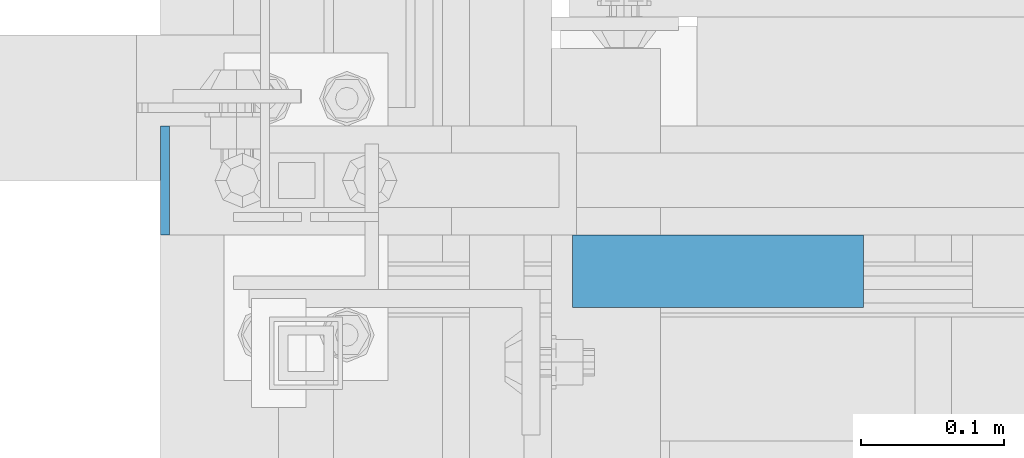
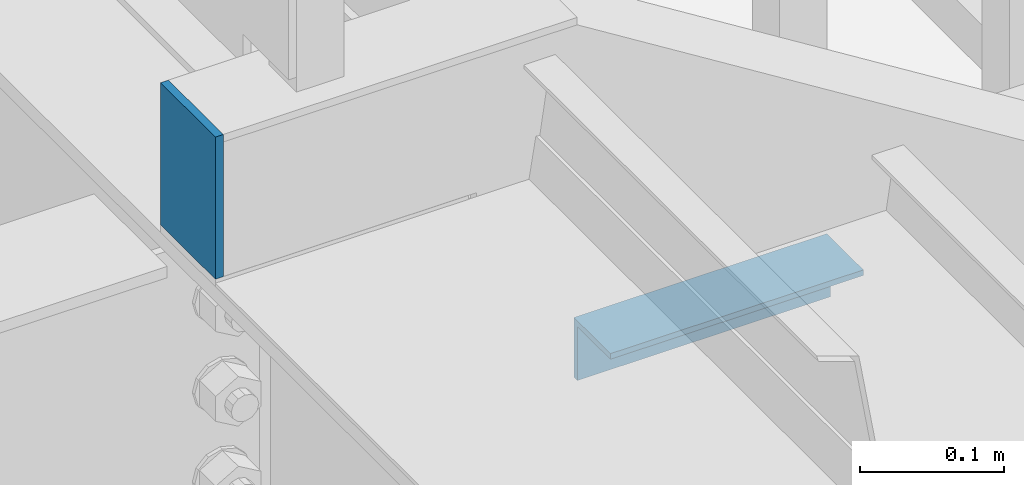
# One storey, part 2073 of 3843: 2 beams, 1 element without a shape of its own.
"""IFC2X3 building model written with IfcOpenShell, lengths in millimetres."""

import ifcopenshell
import ifcopenshell.guid

model = None  # the IFC model being written
_history = None  # IfcOwnerHistory: only IFC2X3 demands one
_inside = {}  # id of a spatial element -> (the spatial element, [elements in it])
_under = {}  # id of a project, library or spatial element -> (it, [spatial elements below it])
_declared = {}  # id of a project -> (the project, [libraries it declares])
_typed = {}  # id of a type object -> (the type object, [elements of that type])
_made_of = {}  # id of a material, layer set ... -> (it, [elements and type objects made of it])


def new_model(schema):
    """Start an empty IFC model of exactly this schema.

    Asked for "IFC4X3", IfcOpenShell would pick the latest addendum, in which some entities
    have other attributes; the version numbers below select the first issue.
    IFC2X3 requires an IfcOwnerHistory on every rooted entity: one is made here for all.
    """
    global model, _history
    if schema == "IFC4X3":
        model = ifcopenshell.file(schema_version=(4, 3, 0, 0))
    else:
        model = ifcopenshell.file(schema=schema)
    _inside.clear()
    _under.clear()
    _declared.clear()
    _typed.clear()
    _made_of.clear()
    _history = None
    if model.schema == "IFC2X3":
        org = make("IfcOrganization", Name="unknown")
        user = make(
            "IfcPersonAndOrganization",
            ThePerson=make("IfcPerson", FamilyName="unknown"),
            TheOrganization=org,
        )
        app = make(
            "IfcApplication",
            ApplicationDeveloper=org,
            Version="unknown",
            ApplicationFullName="unknown",
            ApplicationIdentifier="unknown",
        )
        _history = make(
            "IfcOwnerHistory",
            OwningUser=user,
            OwningApplication=app,
            ChangeAction="ADDED",
            CreationDate=0,
        )
    return model


def make(cls, **values):
    """One entity of the class cls with the attributes given. An attribute that is None is left unset."""
    return model.create_entity(
        cls, **{name: value for name, value in values.items() if value is not None}
    )


def rooted(cls, **values):
    """An entity with a GlobalId (a new one), such as an element, a storey or a relation."""
    return make(cls, GlobalId=ifcopenshell.guid.new(), OwnerHistory=_history, **values)


def si_unit(unit_type, name, prefix=None):
    """IfcSIUnit, for example si_unit("LENGTHUNIT", "METRE", prefix="MILLI")."""
    return make("IfcSIUnit", UnitType=unit_type, Prefix=prefix, Name=name)


def assignment(units):
    """IfcUnitAssignment: the units of a project."""
    return None if units is None else make("IfcUnitAssignment", Units=units)


def point(xyz):
    """IfcCartesianPoint."""
    return None if xyz is None else make("IfcCartesianPoint", Coordinates=xyz)


def direction(xyz):
    """IfcDirection."""
    return None if xyz is None else make("IfcDirection", DirectionRatios=xyz)


def frame(location, z_axis=None, x_axis=None):
    """IfcAxis2Placement3D, a coordinate frame: its origin and axes. An axis left out is left unset."""
    return make(
        "IfcAxis2Placement3D",
        Location=point(location),
        Axis=direction(z_axis),
        RefDirection=direction(x_axis),
    )


def origin_with_axes():
    """The frame at (0, 0, 0) with the z axis (0, 0, 1) and the x axis (1, 0, 0) written out."""
    return frame((0.0, 0.0, 0.0), z_axis=(0.0, 0.0, 1.0), x_axis=(1.0, 0.0, 0.0))


def place(relative_to, where):
    """IfcLocalPlacement: puts the frame where relative to a parent placement (None: the world)."""
    return make(
        "IfcLocalPlacement", PlacementRelTo=relative_to, RelativePlacement=where
    )


def context(
    kind, dimensions, precision=None, world=None, true_north=None, identifier=None
):
    """IfcGeometricRepresentationContext, for example the 3D "Model" context."""
    return make(
        "IfcGeometricRepresentationContext",
        ContextIdentifier=identifier,
        ContextType=kind,
        CoordinateSpaceDimension=dimensions,
        Precision=precision,
        WorldCoordinateSystem=world,
        TrueNorth=true_north,
    )


def subcontext(parent, identifier, kind, view, scale=None):
    """IfcGeometricRepresentationSubContext, for example "Body" below "Model"."""
    return make(
        "IfcGeometricRepresentationSubContext",
        ContextIdentifier=identifier,
        ContextType=kind,
        ParentContext=parent,
        TargetScale=scale,
        TargetView=view,
    )


def project(units=None, contexts=None):
    """IfcProject with its units and contexts."""
    return rooted(
        "IfcProject",
        Name="project",
        RepresentationContexts=contexts,
        UnitsInContext=assignment(units),
    )


def spatial(cls, under=None, at=None, **own):
    """A site, building, storey or space (cls), placed at a placement, below another one or the project."""
    s = rooted(cls, ObjectPlacement=at, **own)
    if under is not None:
        _under.setdefault(under.id(), (under, []))[1].append(s)
    return s


def faces_of(points, faces, orient=None, outer=None):
    """IfcFace entities. A face is a list of loops; a loop is a list of indices into points, from 0.

    orient and outer hold one flag for each loop. By default every Orientation is true, the
    first loop of a face is its IfcFaceOuterBound and the others are IfcFaceBound.
    """
    made = []
    for i, loops in enumerate(faces):
        bounds = []
        for j, loop in enumerate(loops):
            is_outer = j == 0 if outer is None else outer[i][j]
            bounds.append(
                make(
                    "IfcFaceOuterBound" if is_outer else "IfcFaceBound",
                    Bound=make("IfcPolyLoop", Polygon=[points[k] for k in loop]),
                    Orientation=True if orient is None else orient[i][j],
                )
            )
        made.append(make("IfcFace", Bounds=bounds))
    return made


def faceted_brep(points, faces, orient=None, outer=None, voids=None):
    """IfcFacetedBrep: a solid bounded by flat faces; with voids (closed shells), ...WithVoids."""
    shared = [point(p) for p in points]
    hull = make("IfcClosedShell", CfsFaces=faces_of(shared, faces, orient, outer))
    if voids is None:
        return make("IfcFacetedBrep", Outer=hull)
    return make(
        "IfcFacetedBrepWithVoids",
        Outer=hull,
        Voids=[
            make(cls, CfsFaces=faces_of(shared, fs, o, b)) for cls, fs, o, b in voids
        ],
    )


def shape(context_of_items, identifier, shape_type, items):
    """IfcShapeRepresentation: the items that make up one representation, for example the "Body"."""
    return make(
        "IfcShapeRepresentation",
        ContextOfItems=context_of_items,
        RepresentationIdentifier=identifier,
        RepresentationType=shape_type,
        Items=items,
    )


def material(Name=None, Category=None):
    """IfcMaterial."""
    return make("IfcMaterial", Name=Name, Category=Category)


def made_of(thing, what):
    """Note that an element or type object is made of a material, layer set ...; save() writes the relation."""
    if what is not None:
        _made_of.setdefault(what.id(), (what, []))[1].append(thing)
    return thing


def type_object(cls, material=None, **own):
    """A type object (cls), such as IfcWallType, which elements share."""
    return made_of(rooted(cls, **own), material)


def element(
    cls,
    number,
    at=None,
    inside=None,
    cuts=None,
    type_object=None,
    material=None,
    context=None,
    identifier="Body",
    shape_type=None,
    held_by="IfcProductDefinitionShape",
    body=None,
    shapes=None,
    **own,
):
    """One element of the class cls, such as IfcWall. Its Tag is "e" and its number.

    at: its placement. inside: the storey or other place that contains it. cuts: it is an
    opening in that element (IfcRelVoidsElement). A single representation is given by context,
    identifier, shape_type and body (its items); several are given by shapes. held_by: the class
    of the entity that holds the representations. save() writes the other relations.
    """
    e = rooted(cls, Tag="e%d" % number, ObjectPlacement=at, **own)
    if body is not None:
        shapes = [shape(context, identifier, shape_type, body)]
    if shapes is not None:
        e.Representation = make(held_by, Representations=shapes)
    if inside is not None:
        _inside.setdefault(inside.id(), (inside, []))[1].append(e)
    if cuts is not None:
        rooted(
            "IfcRelVoidsElement", RelatingBuildingElement=cuts, RelatedOpeningElement=e
        )
    if type_object is not None:
        _typed.setdefault(type_object.id(), (type_object, []))[1].append(e)
    return made_of(e, material)


def aggregate(whole, parts):
    """IfcRelAggregates: a whole, such as a stair, and the parts it consists of."""
    return rooted("IfcRelAggregates", RelatingObject=whole, RelatedObjects=parts)


def save(model, path):
    """Write the relations noted so far, then the file.

    IfcRelAggregates (storeys below a building ...), IfcRelContainedInSpatialStructure (elements
    in a storey), IfcRelDefinesByType, IfcRelAssociatesMaterial and IfcRelDeclares: one each for
    every whole, place, type object, material and project.
    """
    for whole, parts in _under.values():
        aggregate(whole, parts)
    for where, things in _inside.values():
        rooted(
            "IfcRelContainedInSpatialStructure",
            RelatedElements=things,
            RelatingStructure=where,
        )
    for kind, things in _typed.values():
        rooted("IfcRelDefinesByType", RelatedObjects=things, RelatingType=kind)
    for what, things in _made_of.values():
        rooted("IfcRelAssociatesMaterial", RelatedObjects=things, RelatingMaterial=what)
    for by, libraries in _declared.values():
        rooted("IfcRelDeclares", RelatingContext=by, RelatedDefinitions=libraries)
    model.write(path)


model = new_model("IFC2X3")

# Units and contexts
model_context = context("Model", 3, precision=1e-05, world=origin_with_axes())
body_context = subcontext(model_context, "Body", "Model", "MODEL_VIEW")
ifc_project = project(units=[si_unit("LENGTHUNIT", "METRE", prefix="MILLI"), si_unit("AREAUNIT", "SQUARE_METRE"), si_unit("VOLUMEUNIT", "CUBIC_METRE"), si_unit("MASSUNIT", "GRAM", prefix="KILO"), si_unit("TIMEUNIT", "SECOND"), si_unit("PLANEANGLEUNIT", "RADIAN"), si_unit("SOLIDANGLEUNIT", "STERADIAN"), si_unit("THERMODYNAMICTEMPERATUREUNIT", "DEGREE_CELSIUS"), si_unit("LUMINOUSINTENSITYUNIT", "LUMEN")], contexts=[model_context])

# Site, building, storey
site_placement = place(None, origin_with_axes())
site = spatial("IfcSite", under=ifc_project, at=site_placement, CompositionType="ELEMENT")
building_placement = place(site_placement, origin_with_axes())
building = spatial("IfcBuilding", under=site, at=building_placement, Name="Undefined", CompositionType="ELEMENT")
storey_placement = place(building_placement, origin_with_axes())
storey = spatial("IfcBuildingStorey", under=building, at=storey_placement, Name="Undefined", CompositionType="ELEMENT", Elevation=0.0)

# Assembly, beams
assembly_placement = place(storey_placement, origin_with_axes())
assembly = element("IfcElementAssembly", 1, at=assembly_placement, inside=storey, Name="STAIR", AssemblyPlace="NOTDEFINED", PredefinedType="RIGID_FRAME")
ifc_material_1 = material(Name="STEEL/A36")
beam_type_1 = type_object("IfcBeamType", PredefinedType="NOTDEFINED")
beam_1_placement = place(assembly_placement, frame((52892.3249999999, 22910.8000000929, 37591.9999984863), z_axis=(0.0, -1.0, 0.0), x_axis=(0.0, 0.0, -1.0)))
beam_1 = element("IfcBeam", 2, at=beam_1_placement, type_object=beam_type_1, material=ifc_material_1, Name="PLATE", context=body_context, shape_type="Brep", body=[
    faceted_brep([(0.0, 3.17500000000291, -38.0999999999985), (0.0, 3.17500000000291, 38.0999999999985), (120.650000000831, 3.17500000000291, 38.0999999999985), (120.650000000831, 3.17500000000291, -38.0999999999985), (0.0, -3.17500000000291, 38.0999999999985), (120.650000000831, -3.17500000000291, 38.0999999999985), (0.0, -3.17500000000291, -38.0999999999985), (120.650000000831, -3.17500000000291, -38.0999999999985)], [[[0, 1, 2, 3]], [[1, 4, 5, 2]], [[4, 6, 7, 5]], [[6, 0, 3, 7]], [[5, 7, 3, 2]], [[6, 4, 1, 0]]]),
])
ifc_material_2 = material(Name="STEEL/A572-50")
beam_type_2 = type_object("IfcBeamType", Name="L2X2X3/16", PredefinedType="NOTDEFINED")
beam_2_placement = place(assembly_placement, frame((53176.9934500531, 22847.3000000173, 37312.811665065), z_axis=(0.0, -1.0, 0.0), x_axis=(1.0, 0.0, 0.0)))
beam_2 = element("IfcBeam", 3, at=beam_2_placement, type_object=beam_type_2, material=ifc_material_2, Name="ANGLE", ObjectType="L2X2X3/16", context=body_context, shape_type="Brep", body=[
    faceted_brep([(0.0, 25.4000000000015, -25.4000000000015), (0.0, 25.4000000000015, 25.4000000000015), (203.199999999997, 25.4000000000015, 25.4000000000015), (203.199999999997, 25.4000000000015, -25.4000000000015), (0.0, 20.6375000000007, 25.4000000000015), (203.199999999997, 20.6375000000007, 25.4000000000015), (0.0, 20.6375000000007, -20.6375000000007), (203.199999999997, 20.6375000000007, -20.6375000000007), (0.0, -25.4000000000015, -20.6375000000007), (203.199999999997, -25.4000000000015, -20.6375000000007), (0.0, -25.4000000000015, -25.4000000000015), (203.199999999997, -25.4000000000015, -25.4000000000015)], [[[0, 1, 2, 3]], [[1, 4, 5, 2]], [[4, 6, 7, 5]], [[6, 8, 9, 7]], [[8, 10, 11, 9]], [[10, 0, 3, 11]], [[5, 7, 9, 11, 3, 2]], [[10, 8, 6, 4, 1, 0]]]),
])
aggregate(assembly, [beam_1, beam_2])

save(model, "model.ifc")
